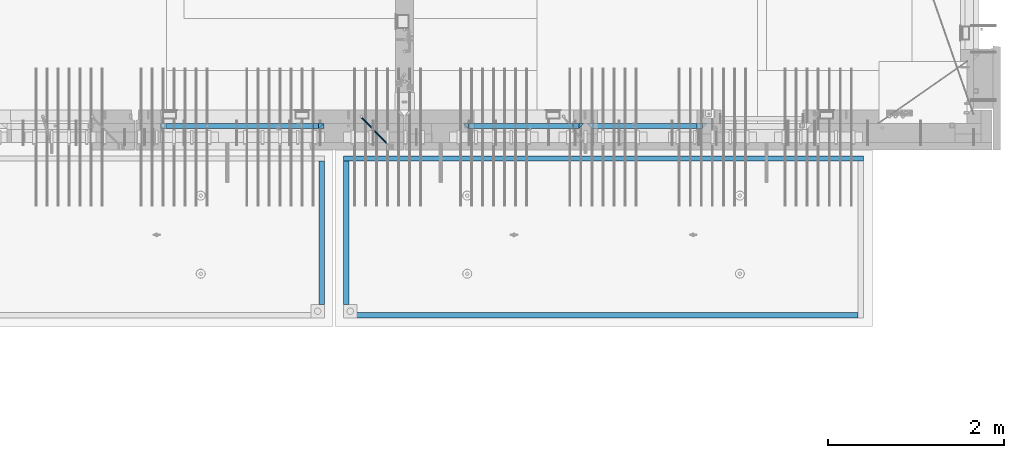
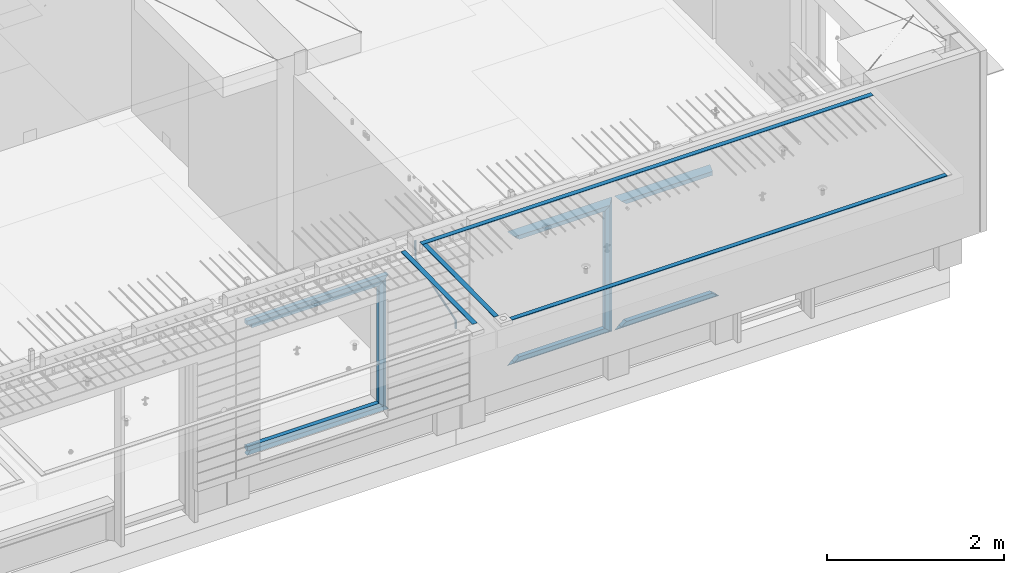
# One storey, part 88 of 325: 21 beams, 4 elements without a shape of their own.
"""IFC2X3 building model written with IfcOpenShell, lengths in millimetres."""

from ifc_helpers import new_model, si_unit, frame, origin_with_axes, place, context, subcontext, project, spatial, faceted_brep, material, type_object, element, aggregate, save


model = new_model("IFC2X3")

# Units and contexts
model_context = context("Model", 3, precision=1e-05, world=origin_with_axes())
body_context = subcontext(model_context, "Body", "Model", "MODEL_VIEW")
ifc_project = project(units=[si_unit("LENGTHUNIT", "METRE", prefix="MILLI"), si_unit("AREAUNIT", "SQUARE_METRE"), si_unit("VOLUMEUNIT", "CUBIC_METRE"), si_unit("MASSUNIT", "GRAM", prefix="KILO"), si_unit("TIMEUNIT", "SECOND"), si_unit("PLANEANGLEUNIT", "RADIAN"), si_unit("SOLIDANGLEUNIT", "STERADIAN"), si_unit("THERMODYNAMICTEMPERATUREUNIT", "DEGREE_CELSIUS"), si_unit("LUMINOUSINTENSITYUNIT", "LUMEN")], contexts=[model_context])

# Site, building, storey
site_placement = place(None, origin_with_axes())
site = spatial("IfcSite", under=ifc_project, at=site_placement, CompositionType="ELEMENT")
building_placement = place(site_placement, origin_with_axes())
building = spatial("IfcBuilding", under=site, at=building_placement, CompositionType="ELEMENT")
storey_placement = place(building_placement, origin_with_axes())
storey = spatial("IfcBuildingStorey", under=building, at=storey_placement, Name="1", CompositionType="ELEMENT", Elevation=0.0)

# Assembly, beam
assembly_1_placement = place(storey_placement, origin_with_axes())
assembly_1 = element("IfcElementAssembly", 1, at=assembly_1_placement, inside=storey, AssemblyPlace="NOTDEFINED", PredefinedType="REINFORCEMENT_UNIT")
ifc_material_1 = material()
beam_type_1 = type_object("IfcBeamType", Name="D20", PredefinedType="NOTDEFINED")
beam_1_placement = place(assembly_1_placement, frame((28120.0219996506, 7924.99999995055, 84407.5), z_axis=(-0.000415599999849952, -0.999999913638316, 0.0), x_axis=(-0.00018169900008877, 0.0, -0.999999983492737)))
beam_1 = element("IfcBeam", 2, at=beam_1_placement, type_object=beam_type_1, material=ifc_material_1, Name="JM20", ObjectType="D20", context=body_context, shape_type="Brep", body=[
    faceted_brep([(-0.00060564729210455, -9.99999998165731, 0.0), (-0.000428079845733009, -7.07106779890455, -7.07106781186667), (119.575515501536, -7.07830994756296, -7.07106481604933), (119.575337932896, -10.0072421307195, -3.43332612828817e-06), (0.0, 0.0, -10.0), (119.575943836026, -0.00724214867295814, -9.99999700418266), (0.00042843479604926, 7.07106779888636, -7.07106781186303), (119.57637202373, 7.06382565022977, -7.07106481604933), (0.00060564729210455, 9.99999998166459, 3.63797880709171e-12), (119.576549238118, 9.99275783300072, 2.99581552098971e-06), (0.000428079845733009, 7.07106779890819, 7.07106781186667), (119.576371669405, 7.06382565024978, 7.07107080768037), (0.0, 0.0, 10.0), (119.57594333493, -0.00724214864203532, 10.0000029958155), (-0.000428434810601175, -7.07106779888272, 7.07106781186667), (119.575515147211, -7.07830994754295, 7.07107080768037), (123.007838984922, -7.07805953274146, -6.96781646693489), (122.583416564885, -10.0070226667376, 0.0904895847234002), (123.182432386879, -0.00697902713727672, -9.89150957511447), (123.004922326727, 7.0640757898218, -6.96792996825661), (122.579291790258, 9.99297690664025, 0.09032907062101), (122.154869373029, 7.06401377197108, 7.14863512328429), (121.980275971029, -0.00706673364766175, 10.0723282314621), (122.157786031181, -7.0781215506031, 7.1487486246051), (232.991069545737, -7.0553235628031, -0.344989315878593), (232.56664713427, -9.98428669916029, 6.71331673826626), (233.165662947809, 0.0157569427356066, -3.26868242414184), (232.988152887861, 7.08681175970924, -0.345102817348561), (232.562522351524, 10.0157128766077, 6.71315622151724), (232.138099934426, 7.08674974201131, 13.7714622742333), (231.963506532353, 0.0156692364653281, 16.6951553824965), (232.141016592301, -7.05538558050466, 13.7715757757042), (248.076986635424, -5.5847993905918, 1.85861828010275), (247.029610002806, -8.57448599522468, 8.8259290931519), (244.875536996158, -5.81406760439131, 15.6317136598209), (242.87659436863, 1.07944012639928, 18.2892356835691), (242.20373560088, 8.06791386077748, 15.2417548051744), (243.251112233527, 11.0576004654249, 8.27444399212709), (245.405185240103, 8.29718207458427, 1.4686594254481), (247.40412786763, 1.40367434377549, -1.1888625983047), (260.566830172145, 5.47100196453175, 3.19131575132906), (262.023113325369, -1.27539050352425, 6.49949830426976), (256.884070167318, 11.8442033958454, 5.28851055269934), (253.132144174728, 14.110878827727, 11.5625744366826), (251.508879555811, 10.9432405336265, 18.3382458712176), (252.965162709021, 4.19684806558143, 21.6464284241465), (256.647922713819, -2.17635336575768, 19.5492336227662), (260.399848700399, -4.44302879667157, 13.2751697364092), (1011.72756124764, 322.959435794994, 337.688425673249), (1010.10429662876, 319.79179750097, 344.464097107826), (1010.27127809466, 329.705828263024, 334.380243120345), (1006.58851809015, 336.079029694381, 336.477437921801), (1002.83659209782, 338.345705126318, 342.751501805859), (1001.21332747894, 335.178066832297, 349.527173240437), (1002.66961063194, 328.431674364263, 352.835355793341), (1006.35237063644, 322.058472932906, 350.738160991886), (1012.15285167976, 323.143366902459, 337.876301685487), (1011.27592458235, 320.298507294498, 344.981674676291), (1011.36533099508, 330.178988123705, 334.863551186057), (1009.37468146477, 337.283999466545, 337.708251560521), (1007.34699858574, 340.296381647149, 344.744015910405), (1006.47007148832, 337.45152203918, 351.849388901209), (1007.25759217299, 330.415900817941, 354.862139400639), (1009.24824170329, 323.310889475106, 352.017439026175), (1012.6528516715, 323.14345775195, 337.876301647731), (1012.65336908352, 320.298757574768, 344.981674572278), (1012.65157305435, 330.179221832586, 334.863551088932), (1012.65028222866, 337.284594639881, 337.708251313175), (1012.64973534261, 340.297345149043, 344.744015509988), (1012.65025275464, 337.452644971851, 351.849388434534), (1012.65153137178, 330.416880891225, 354.862138993334), (1012.65282219746, 323.311508083931, 352.017438769089), (1117.44132683994, 323.162497711652, 337.876293734989), (1117.44184425197, 320.31779753447, 344.981666659536), (1117.44004822278, 330.198261792288, 334.863543176189), (1117.43875739709, 337.303634599582, 337.708243400433), (1117.43821051104, 340.316385108745, 344.744007597245), (1117.43872792307, 337.471684931556, 351.849380521792), (1117.44000654022, 330.435920850927, 354.862131080592), (1117.44129736591, 323.330548043632, 352.017430856347)], [[[0, 1, 2, 3]], [[1, 4, 5, 2]], [[4, 6, 7, 5]], [[6, 8, 9, 7]], [[8, 10, 11, 9]], [[10, 12, 13, 11]], [[12, 14, 15, 13]], [[14, 0, 3, 15]], [[14, 12, 10, 8, 6, 4, 1, 0]], [[3, 2, 16, 17]], [[2, 5, 18, 16]], [[5, 7, 19, 18]], [[7, 9, 20, 19]], [[9, 11, 21, 20]], [[11, 13, 22, 21]], [[13, 15, 23, 22]], [[15, 3, 17, 23]], [[17, 16, 24, 25]], [[16, 18, 26, 24]], [[18, 19, 27, 26]], [[19, 20, 28, 27]], [[20, 21, 29, 28]], [[21, 22, 30, 29]], [[22, 23, 31, 30]], [[23, 17, 25, 31]], [[25, 24, 32, 33]], [[31, 25, 33, 34]], [[30, 31, 34, 35]], [[29, 30, 35, 36]], [[28, 29, 36, 37]], [[27, 28, 37, 38]], [[26, 27, 38, 39]], [[24, 26, 39, 32]], [[39, 40, 41, 32]], [[38, 42, 40, 39]], [[37, 43, 42, 38]], [[36, 44, 43, 37]], [[35, 45, 44, 36]], [[34, 46, 45, 35]], [[33, 47, 46, 34]], [[32, 41, 47, 33]], [[47, 41, 48, 49]], [[41, 40, 50, 48]], [[40, 42, 51, 50]], [[42, 43, 52, 51]], [[43, 44, 53, 52]], [[44, 45, 54, 53]], [[45, 46, 55, 54]], [[46, 47, 49, 55]], [[49, 48, 56, 57]], [[48, 50, 58, 56]], [[50, 51, 59, 58]], [[51, 52, 60, 59]], [[52, 53, 61, 60]], [[53, 54, 62, 61]], [[54, 55, 63, 62]], [[55, 49, 57, 63]], [[57, 56, 64, 65]], [[56, 58, 66, 64]], [[58, 59, 67, 66]], [[59, 60, 68, 67]], [[60, 61, 69, 68]], [[61, 62, 70, 69]], [[62, 63, 71, 70]], [[63, 57, 65, 71]], [[65, 64, 72, 73]], [[64, 66, 74, 72]], [[66, 67, 75, 74]], [[67, 68, 76, 75]], [[68, 69, 77, 76]], [[69, 70, 78, 77]], [[70, 71, 79, 78]], [[71, 65, 73, 79]], [[74, 75, 76, 77, 78, 79, 73, 72]]]),
])

# Assembly, beams
assembly_2_placement = place(storey_placement, origin_with_axes())
assembly_2 = element("IfcElementAssembly", 3, at=assembly_2_placement, inside=storey, AssemblyPlace="NOTDEFINED", PredefinedType="REINFORCEMENT_UNIT")
ifc_material_2 = material(Name="CONCRETE/Concrete_Undefined")
beam_type_2 = type_object("IfcBeamType", PredefinedType="NOTDEFINED")
beam_2_placement = place(assembly_2_placement, frame((27949.9413896323, 7420.0548526853, 84725.6636564041), z_axis=(3.20999999465459e-07, -0.00901957599816896, 0.999959322797038), x_axis=(3.55380000057318e-05, -0.999959322165559, -0.00901957600149657)))
beam_2 = element("IfcBeam", 4, at=beam_2_placement, type_object=beam_type_2, material=ifc_material_2, context=body_context, shape_type="Brep", body=[
    faceted_brep([(2.5465851649642e-11, 29.9999999999982, -4.99999999998545), (-2.91038304567337e-11, 29.9999999999982, 5.0), (1625.35189228369, 30.0000000000073, 5.0), (1625.35189228371, 30.0000000000073, -5.0), (-2.5465851649642e-11, -30.0000000000018, 5.0), (1625.35189228368, -29.9999999999927, 5.00000000001455), (2.72848410531878e-11, -30.0000000000018, -4.99999999998545), (1625.35189228371, -29.9999999999927, -4.99999999998545)], [[[0, 1, 2, 3]], [[1, 4, 5, 2]], [[4, 6, 7, 5]], [[6, 0, 3, 7]], [[5, 7, 3, 2]], [[6, 4, 1, 0]]]),
])
beam_3_placement = place(assembly_2_placement, frame((33810.0034098489, 7449.93184428067, 84725.278844281), z_axis=(6.5298999993069e-05, -1.00000033840378e-09, 0.99999999786802), x_axis=(-0.999999997792817, 1.22639999974798e-05, 6.52989999859729e-05)))
beam_3 = element("IfcBeam", 5, at=beam_3_placement, type_object=beam_type_2, material=ifc_material_2, context=body_context, shape_type="Brep", body=[
    faceted_brep([(2.5465851649642e-11, 29.9999999999982, -4.99999999998545), (-2.91038304567337e-11, 29.9999999999982, 5.0), (5890.06001043805, 29.9999999999991, 5.00000000001455), (5890.06001043806, 30.0, -4.99999999998545), (-2.5465851649642e-11, -30.0000000000018, 5.0), (5890.06001043806, -30.0, 5.00000000001455), (2.72848410531878e-11, -30.0000000000018, -4.99999999998545), (5890.06001043806, -30.0, -5.0)], [[[0, 1, 2, 3]], [[1, 4, 5, 2]], [[4, 6, 7, 5]], [[6, 0, 3, 7]], [[5, 7, 3, 2]], [[6, 4, 1, 0]]]),
])
beam_4_placement = place(assembly_2_placement, frame((33750.1798578673, 5674.89208457699, 84711.2777998596), z_axis=(-0.00010875600001081, -1.00000033862182e-09, 0.999999994086066), x_axis=(-0.999999994070015, -5.66600000038745e-06, -0.000108756000006807)))
beam_4 = element("IfcBeam", 6, at=beam_4_placement, type_object=beam_type_2, material=ifc_material_2, context=body_context, shape_type="Brep", body=[
    faceted_brep([(2.5465851649642e-11, 29.9999999999982, -4.99999999998545), (-2.91038304567337e-11, 29.9999999999982, 5.0), (5682.56261276337, 30.0, 5.0), (5682.56261276337, 30.0, -5.0), (-2.5465851649642e-11, -30.0000000000018, 5.0), (5682.56261276337, -30.0, 5.0), (2.72848410531878e-11, -30.0000000000018, -4.99999999998545), (5682.56261276337, -30.0, -5.0)], [[[0, 1, 2, 3]], [[1, 4, 5, 2]], [[4, 6, 7, 5]], [[6, 0, 3, 7]], [[5, 7, 3, 2]], [[6, 4, 1, 0]]]),
])
aggregate(assembly_2, [beam_2, beam_3, beam_4])

# Assembly, beam
assembly_3_placement = place(storey_placement, origin_with_axes())
assembly_3 = element("IfcElementAssembly", 7, at=assembly_3_placement, inside=storey, AssemblyPlace="NOTDEFINED", PredefinedType="REINFORCEMENT_UNIT")
beam_5_placement = place(assembly_3_placement, frame((27670.0013901304, 7419.94686420498, 84725.2791047129), z_axis=(-7.99999906695021e-09, -0.0106298469955396, 0.99994350158039), x_axis=(-7.67999998664137e-07, -0.999943501580095, -0.0106298469955353)))
beam_5 = element("IfcBeam", 8, at=beam_5_placement, type_object=beam_type_2, material=ifc_material_2, context=body_context, shape_type="Brep", body=[
    faceted_brep([(2.5465851649642e-11, 29.9999999999982, -4.99999999998545), (-2.91038304567337e-11, 29.9999999999982, 5.0), (1625.17584384035, 29.9999999999964, 5.0), (1625.17584384035, 30.0000000000036, -4.99999999998545), (-2.5465851649642e-11, -30.0000000000018, 5.0), (1625.17584384035, -30.0, 5.0), (2.72848410531878e-11, -30.0000000000018, -4.99999999998545), (1625.17584384035, -29.9999999999964, -4.99999999998545)], [[[0, 1, 2, 3]], [[1, 4, 5, 2]], [[4, 6, 7, 5]], [[6, 0, 3, 7]], [[5, 7, 3, 2]], [[6, 4, 1, 0]]]),
])
aggregate(assembly_3, [beam_5])

# Beam
ifc_material_3 = material(Name="CONCRETE/C35/45")
beam_type_3 = type_object("IfcBeamType", PredefinedType="NOTDEFINED")
beam_6_placement = place(assembly_1_placement, frame((25845.0006272121, 7820.0, 84145.0), z_axis=(0.0, 0.0, -1.0), x_axis=(1.0, 0.0, 0.0)))
beam_6 = element("IfcBeam", 9, at=beam_6_placement, type_object=beam_type_3, material=ifc_material_3, Name="SK", context=body_context, shape_type="Brep", body=[
    faceted_brep([(0.0, -30.0, -30.0), (0.0, -30.0, 30.0), (-5.28234522789717e-09, 30.0, 30.0), (0.0, 30.0, -30.0), (1849.99885559082, -30.0, -30.0), (1789.99885559081, -30.0, 30.0), (1789.99885559081, 30.0, 30.0), (1849.99885559082, 30.0, -30.0)], [[[0, 1, 2, 3]], [[1, 0, 4, 5]], [[2, 1, 5, 6]], [[3, 2, 6, 7]], [[0, 3, 7, 4]], [[6, 5, 4, 7]]]),
])

beam_7_placement = place(assembly_1_placement, frame((25905.0006272121, 7820.0, 84085.0), z_axis=(0.0, 0.0, -1.0), x_axis=(1.0, 0.0, 0.0)))
beam_7 = element("IfcBeam", 10, at=beam_7_placement, type_object=beam_type_3, material=ifc_material_3, Name="SK", context=body_context, shape_type="Brep", body=[
    faceted_brep([(1665.94480153677, -30.0, 24.0540540540533), (1664.32317991515, 30.0, 25.6756756756804), (0.0, 30.0, 25.6756756756804), (0.0, -30.0, 24.0540540540678), (0.0, 30.0, -30.0), (0.0, -30.0, -30.0), (1729.99885559082, -30.0, -30.0), (1665.94480153677, -30.0, 24.9034748914419), (1664.32317991515, 30.0, 26.293436281092), (1729.99885559082, 30.0, -30.0)], [[[0, 1, 2, 3]], [[4, 5, 3, 2]], [[0, 3, 5, 6, 7]], [[1, 0, 7, 8]], [[4, 2, 1, 8, 9]], [[5, 4, 9, 6]], [[8, 7, 6, 9]]]),
])

beam_8_placement = place(assembly_1_placement, frame((27664.9994828029, 7820.0, 84175.0), z_axis=(-1.0, 3.00000001838171e-08, 0.0), x_axis=(0.0, 0.0, -1.0)))
beam_8 = element("IfcBeam", 11, at=beam_8_placement, type_object=beam_type_3, material=ifc_material_3, Name="SK", context=body_context, shape_type="Brep", body=[
    faceted_brep([(60.0000000000073, 30.0, 30.0), (0.0, -30.0, -30.0), (60.0000000000073, -30.0, 30.0), (1855.0, -30.0, -30.0), (1795.00000000001, -30.0, 30.0), (1795.00000000001, 30.0, 30.0)], [[[0, 1, 2]], [[3, 4, 2, 1]], [[4, 5, 0, 2]], [[5, 3, 1, 0]], [[4, 3, 5]]]),
])

beam_9_placement = place(assembly_1_placement, frame((27694.9994828029, 7820.0, 82350.0), z_axis=(0.0, 0.0, 1.0), x_axis=(-1.0, 3.00000001838171e-08, 0.0)))
beam_9 = element("IfcBeam", 12, at=beam_9_placement, type_object=beam_type_3, material=ifc_material_3, Name="SK", context=body_context, shape_type="Brep", body=[
    faceted_brep([(1849.99885559082, 30.0, -30.0), (1800.18119326315, 30.0, 30.0), (1800.18119326315, -30.0, 30.0), (1849.99885559082, -30.0, -30.0), (0.0, -30.0, -30.0), (0.0, 30.0, -30.0), (60.0000000000073, 30.0, 30.0), (60.0000000000073, -30.0, 30.0)], [[[0, 1, 2, 3]], [[4, 5, 0, 3]], [[1, 0, 5, 6]], [[2, 1, 6, 7]], [[3, 2, 7, 4]], [[6, 5, 4, 7]]]),
])

beam_10_placement = place(assembly_1_placement, frame((27634.9994828029, 7820.0, 82410.0), z_axis=(0.0, 0.0, 1.0), x_axis=(-1.0, 3.00000001838171e-08, 0.0)))
beam_10 = element("IfcBeam", 13, at=beam_10_placement, type_object=beam_type_3, material=ifc_material_3, Name="SK", context=body_context, shape_type="Brep", body=[
    faceted_brep([(1785.94885559082, 30.0, 30.0), (1784.32432432432, 30.0, 30.0), (1785.94885559082, -30.0, 30.0), (1785.94885559082, -30.0, 24.0540519302303), (1784.32432432433, 30.0, 25.6756756756804), (65.6756756756768, 30.0, 25.6756756756804), (64.0540540540533, -30.0, 24.0540540540533), (1785.94885559082, -30.0, -30.0), (1785.94885559082, 30.0, -30.0), (0.0, -30.0, -30.0), (0.0, 30.0, -30.0), (65.6756756756768, 30.0, 26.293436281092), (64.0540540540533, -30.0, 24.9034748914419)], [[[0, 1, 2]], [[3, 4, 5, 6]], [[1, 4, 3, 2]], [[7, 8, 0, 2, 3]], [[8, 7, 9, 10]], [[5, 4, 1, 0, 8, 10, 11]], [[6, 5, 11, 12]], [[7, 3, 6, 12, 9]], [[9, 12, 11, 10]]]),
])

# Assembly, beams
assembly_4_placement = place(storey_placement, origin_with_axes())
assembly_4 = element("IfcElementAssembly", 14, at=assembly_4_placement, inside=storey, AssemblyPlace="NOTDEFINED", PredefinedType="REINFORCEMENT_UNIT")
beam_11_placement = place(assembly_4_placement, frame((30674.9996552717, 7820.0, 84145.0), z_axis=(0.0, 0.0, -1.0), x_axis=(1.0, 0.0, 0.0)))
beam_11 = element("IfcBeam", 15, at=beam_11_placement, type_object=beam_type_3, material=ifc_material_3, Name="SK", context=body_context, shape_type="Brep", body=[
    faceted_brep([(1249.99847412109, -30.0, 30.0), (1249.99847412109, -29.999999998452, -30.0), (1249.99847412109, 30.0, 30.0), (60.0000000000073, -30.0, 30.0), (0.0, -30.0, -30.0), (60.0000000000073, 30.0, 30.0)], [[[0, 1, 2]], [[1, 0, 3, 4]], [[2, 1, 4, 5]], [[0, 2, 5, 3]], [[5, 4, 3]]]),
])
beam_12_placement = place(assembly_4_placement, frame((30734.9996552717, 7820.0, 84085.0), z_axis=(0.0, 0.0, -1.0), x_axis=(1.0, 0.0, 0.0)))
beam_12 = element("IfcBeam", 16, at=beam_12_placement, type_object=beam_type_3, material=ifc_material_3, Name="SK", context=body_context, shape_type="Brep", body=[
    faceted_brep([(1189.99847412109, -30.0, 30.0), (1189.99847412109, -30.0, -30.0), (1189.99847412109, 30.0, -30.0), (1189.99847412109, 30.0, 30.0), (1184.32279844542, 30.0, 30.0), (1185.94442006704, -30.0, 30.0), (1184.32279844542, 29.999999998452, 25.6756756756804), (1185.94442006696, -29.999999998452, 24.0540540541406), (65.6741497967687, 29.999999998452, 25.6756756756804), (64.0525281752307, -29.999999998452, 24.0540540541406), (65.6741497967687, 29.999999998452, 26.2921283848846), (64.0525281752307, -29.999999998452, 24.9021669953072), (0.0, -30.0, -30.0), (0.0, 30.0, -30.0)], [[[0, 1, 2, 3]], [[0, 3, 4, 5]], [[5, 4, 6, 7]], [[7, 6, 8, 9]], [[9, 8, 10, 11]], [[1, 0, 5, 7, 9, 11, 12]], [[2, 1, 12, 13]], [[8, 6, 4, 3, 2, 13, 10]], [[10, 13, 12, 11]]]),
])
ifc_material_4 = material(Name="CONCRETE/C30/37")
beam_13_placement = place(assembly_4_placement, frame((32044.9981293928, 7820.0, 82350.0), z_axis=(0.0, 0.0, 1.0), x_axis=(-1.0, 3.00000001838171e-08, 0.0)))
beam_13 = element("IfcBeam", 17, at=beam_13_placement, type_object=beam_type_3, material=ifc_material_4, Name="SK", context=body_context, shape_type="Brep", body=[
    faceted_brep([(1309.99847412109, 30.0, 30.0), (1309.99847412109, -30.0, 30.0), (1369.99847412109, -30.0, -30.0), (0.0, -30.0, -30.0), (60.0000000000073, 30.0, 30.0), (60.0000000000073, -30.0, 30.0)], [[[0, 1, 2]], [[3, 4, 0, 2]], [[4, 5, 1, 0]], [[5, 3, 2, 1]], [[4, 3, 5]]]),
])
beam_14_placement = place(assembly_4_placement, frame((31984.9981293928, 7820.0, 82410.0), z_axis=(0.0, 0.0, 1.0), x_axis=(-1.0, 3.00000001838171e-08, 0.0)))
beam_14 = element("IfcBeam", 18, at=beam_14_placement, type_object=beam_type_3, material=ifc_material_3, Name="SK", context=body_context, shape_type="Brep", body=[
    faceted_brep([(1185.94594588314, -29.9999988381387, 24.0540541168593), (1184.32432432432, 29.9999988381387, 25.6756756756804), (65.6756756756768, 30.0, 25.6756756756804), (64.0540540540533, -30.0, 24.0540540540533), (1185.94594594586, -29.999999998452, 24.9021669952926), (1184.32432432433, 29.999999998452, 26.2921283848846), (1249.99847412109, -29.999999998452, -30.0), (1249.99847412109, 29.999999998452, -30.0), (0.0, -30.0, -30.0), (0.0, 30.0, -30.0), (65.6756756756768, 30.0, 26.293436281092), (64.0540540540533, -30.0, 24.9034748914419)], [[[0, 1, 2, 3]], [[1, 0, 4, 5]], [[5, 4, 6, 7]], [[8, 9, 7, 6]], [[2, 1, 5, 7, 9, 10]], [[3, 2, 10, 11]], [[6, 4, 0, 3, 11, 8]], [[8, 11, 10, 9]]]),
])
beam_15_placement = place(assembly_4_placement, frame((29275.0000367414, 7820.0, 84145.0), z_axis=(0.0, 0.0, -1.0), x_axis=(1.0, 0.0, 0.0)))
beam_15 = element("IfcBeam", 19, at=beam_15_placement, type_object=beam_type_3, material=ifc_material_3, Name="SK", context=body_context, shape_type="Brep", body=[
    faceted_brep([(60.0000000000073, 30.0, 30.0), (0.0, -30.0, -30.0), (60.0000000000073, -30.0, 30.0), (1370.00038146973, -30.0, -30.0), (1310.0003814697, -30.0, 30.0), (1310.0003814697, 30.0, 30.0)], [[[0, 1, 2]], [[2, 1, 3, 4]], [[0, 2, 4, 5]], [[1, 0, 5, 3]], [[3, 5, 4]]]),
])
beam_16_placement = place(assembly_4_placement, frame((29335.0000367414, 7820.0, 84085.0), z_axis=(0.0, 0.0, -1.0), x_axis=(1.0, 0.0, 0.0)))
beam_16 = element("IfcBeam", 20, at=beam_16_placement, type_object=beam_type_3, material=ifc_material_3, Name="SK", context=body_context, shape_type="Brep", body=[
    faceted_brep([(1185.94632735287, -29.9999988381387, 24.0540541168593), (1184.32470579405, 29.9999988381387, 25.6756756756804), (65.6760571454033, 29.9999988381387, 25.6756756756804), (64.0544355865859, -29.9999988381387, 24.0540541168593), (65.6760571454033, 29.9999988381387, 26.2937632551475), (64.0544355865859, -29.9999988381387, 24.9038019193104), (0.0, 30.0, -30.0), (0.0, -30.0, -30.0), (1250.00038146973, -29.9999988381387, -30.0), (1185.94632735287, -29.9999988381387, 24.9034749452549), (1184.32470579405, 29.9999988381387, 26.2934362810629), (1250.00038146973, 29.9999988381387, -30.0)], [[[0, 1, 2, 3]], [[3, 2, 4, 5]], [[5, 4, 6, 7]], [[0, 3, 5, 7, 8, 9]], [[1, 0, 9, 10]], [[6, 4, 2, 1, 10, 11]], [[7, 6, 11, 8]], [[8, 11, 10, 9]]]),
])
beam_17_placement = place(assembly_4_placement, frame((30615.0004182112, 7820.0, 84175.0), z_axis=(-1.0, 3.00000001838171e-08, 0.0), x_axis=(0.0, 0.0, -1.0)))
beam_17 = element("IfcBeam", 21, at=beam_17_placement, type_object=beam_type_3, material=ifc_material_4, Name="SK", context=body_context, shape_type="Brep", body=[
    faceted_brep([(60.0000000000073, 30.0, 30.0), (0.0, -30.0, -30.0), (60.0000000000073, -30.0, 30.0), (1855.0, -30.0, -30.0), (1795.00000000001, -30.0, 30.0), (1795.00000000001, 30.0, 30.0)], [[[0, 1, 2]], [[3, 4, 2, 1]], [[4, 5, 0, 2]], [[5, 3, 1, 0]], [[4, 3, 5]]]),
])
beam_18_placement = place(assembly_4_placement, frame((30645.0004182112, 7820.0, 82350.0), z_axis=(0.0, 0.0, 1.0), x_axis=(-1.0, 3.00000001838171e-08, 0.0)))
beam_18 = element("IfcBeam", 22, at=beam_18_placement, type_object=beam_type_3, material=ifc_material_4, Name="SK", context=body_context, shape_type="Brep", body=[
    faceted_brep([(1370.00038146973, -30.0, -30.0), (1310.0003814697, 30.0, 30.0), (1310.0003814697, -30.0, 30.0), (0.0, -30.0, -30.0), (60.0000000000073, 30.0, 30.0), (60.0000000000073, -30.0, 30.0)], [[[0, 1, 2]], [[3, 4, 1, 0]], [[4, 5, 2, 1]], [[5, 3, 0, 2]], [[4, 3, 5]]]),
])
beam_19_placement = place(assembly_4_placement, frame((30585.0004182112, 7820.0, 82410.0), z_axis=(0.0, 0.0, 1.0), x_axis=(-1.0, 3.00000001838171e-08, 0.0)))
beam_19 = element("IfcBeam", 23, at=beam_19_placement, type_object=beam_type_3, material=ifc_material_3, Name="SK", context=body_context, shape_type="Brep", body=[
    faceted_brep([(1185.94594588314, -29.9999988381387, 24.0540541168593), (1184.32432432432, 29.9999988381387, 25.6756756756804), (65.6756756756768, 30.0, 25.6756756756804), (64.0540540540533, -30.0, 24.0540540540533), (1185.94594588314, -29.9999988381387, 24.9038019193104), (1184.32432432432, 29.9999988381387, 26.2937632551329), (1250.00038146973, -29.9999988381387, -30.0), (1250.00038146973, 29.9999988381387, -30.0), (0.0, -30.0, -30.0), (0.0, 30.0, -30.0), (65.6756756756768, 30.0, 26.293436281092), (64.0540540540533, -30.0, 24.9034748914419)], [[[0, 1, 2, 3]], [[1, 0, 4, 5]], [[4, 6, 7, 5]], [[8, 9, 7, 6]], [[2, 1, 5, 7, 9, 10]], [[3, 2, 10, 11]], [[6, 4, 0, 3, 11, 8]], [[8, 11, 10, 9]]]),
])

# Beam
beam_type_4 = type_object("IfcBeamType", PredefinedType="NOTDEFINED")
beam_20_placement = place(assembly_1_placement, frame((27599.9994828029, 7820.0, 84115.0), z_axis=(-1.0, 3.00000001838171e-08, 0.0), x_axis=(0.0, 0.0, -1.0)))
beam_20 = element("IfcBeam", 24, at=beam_20_placement, type_object=beam_type_4, material=ifc_material_3, Name="SK", context=body_context, shape_type="Brep", body=[
    faceted_brep([(0.0, -30.0, -35.0), (54.9034748914273, -30.0, 29.0540540540533), (56.2934362811066, 30.0, 30.6756756756768), (0.0, 30.0, -35.0), (1735.0, -30.0, -35.0), (1680.09652510857, -30.0, 29.0540540540533), (1678.70656371891, 30.0, 30.6756756756768), (1735.0, 30.0, -35.0)], [[[0, 1, 2, 3]], [[1, 0, 4, 5]], [[2, 1, 5, 6]], [[3, 2, 6, 7]], [[7, 4, 0, 3]], [[4, 7, 6, 5]]]),
])

aggregate(assembly_1, [beam_1, beam_6, beam_7, beam_8, beam_20, beam_9, beam_10])

beam_21_placement = place(assembly_4_placement, frame((30550.0004182112, 7820.0, 84115.0), z_axis=(-1.0, 3.00000001838171e-08, 0.0), x_axis=(0.0, 0.0, -1.0)))
beam_21 = element("IfcBeam", 25, at=beam_21_placement, type_object=beam_type_4, material=ifc_material_3, Name="SK", context=body_context, shape_type="Brep", body=[
    faceted_brep([(0.0, -30.0, -35.0), (54.9034748914273, -30.0, 29.0540540540533), (56.2934362811066, 30.0, 30.6756756756768), (0.0, 30.0, -35.0), (1735.0, -30.0, -35.0), (1680.09652510857, -30.0, 29.0540540540533), (1678.70656371891, 30.0, 30.6756756756768), (1735.0, 30.0, -35.0)], [[[0, 1, 2, 3]], [[1, 0, 4, 5]], [[2, 1, 5, 6]], [[3, 2, 6, 7]], [[7, 4, 0, 3]], [[4, 7, 6, 5]]]),
])

aggregate(assembly_4, [beam_11, beam_12, beam_13, beam_14, beam_15, beam_16, beam_17, beam_21, beam_18, beam_19])

save(model, "model.ifc")
